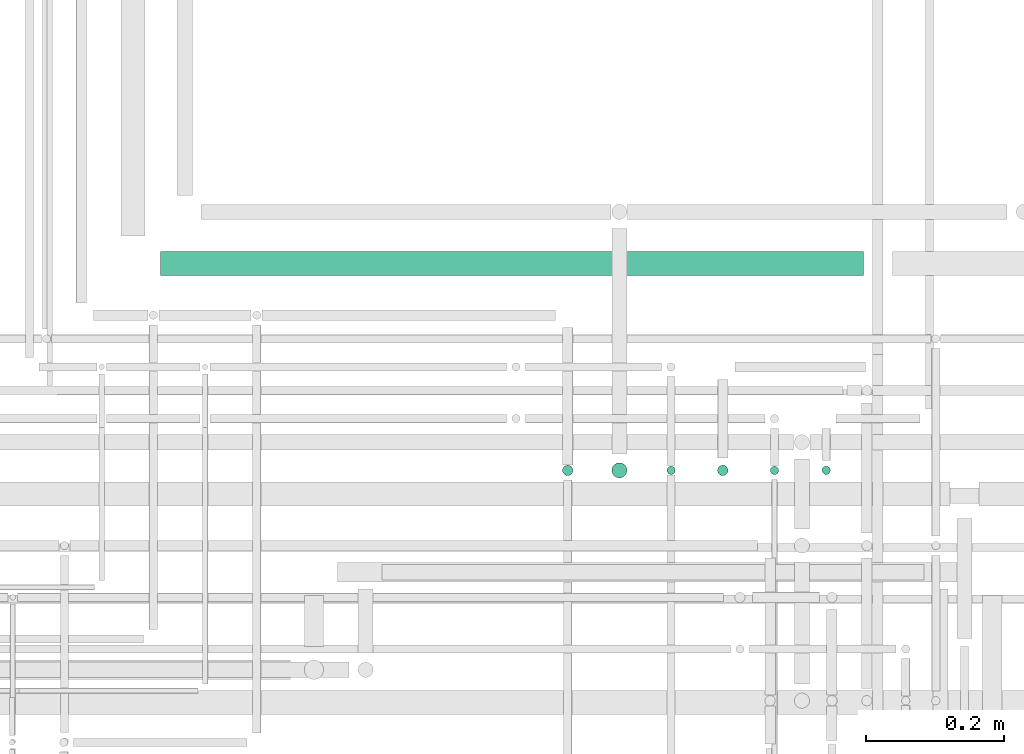
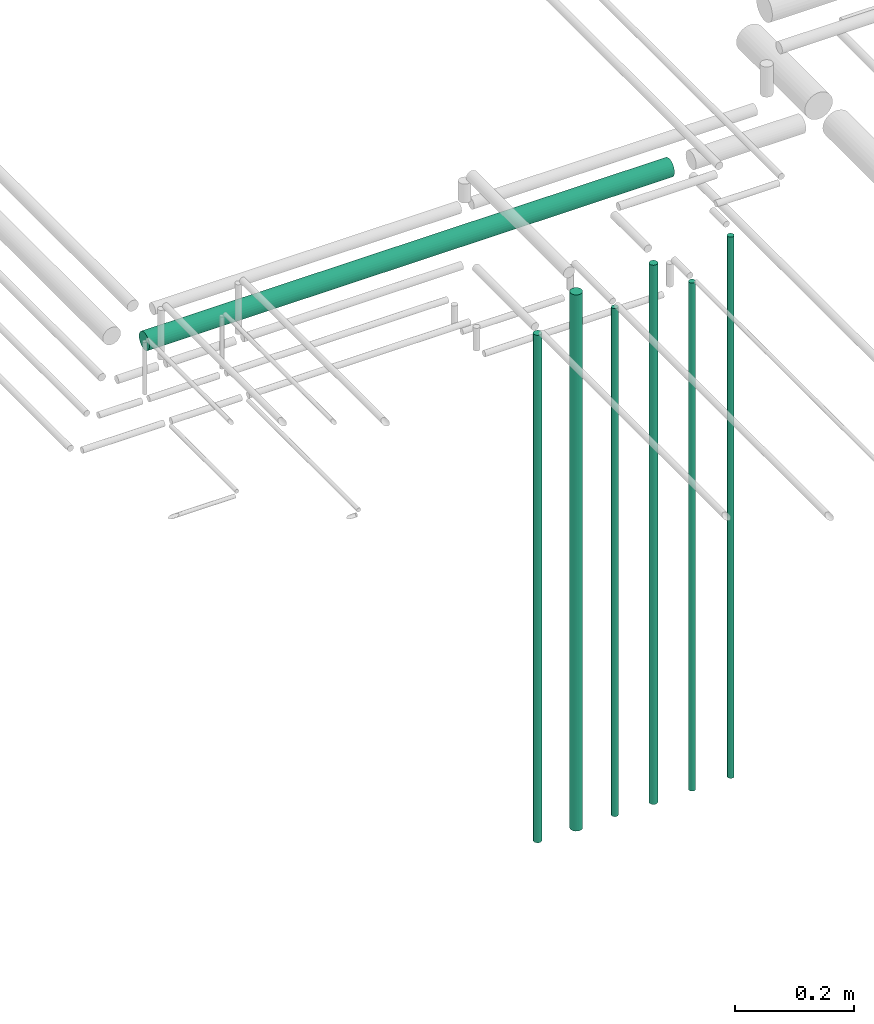
# One storey, part 84 of 331: 7 flow segments.
"""IFC2X3 building model written with IfcOpenShell, lengths in millimetres."""

from ifc_helpers import new_model, entity, si_unit, converted_unit, derived_unit, direction, frame, frame_2d, origin, origin_2d_with_axis, place, context, subcontext, project, spatial, circle, extrude, type_object, element, save


model = new_model("IFC2X3")

# Units and contexts
model_context = context("Model", 3, precision=0.01, world=origin(), true_north=direction((6.12303176911189e-17, 1.0)))
body_context = subcontext(model_context, "Body", "Model", "MODEL_VIEW")
ifc_project = project(units=[si_unit("LENGTHUNIT", "METRE", prefix="MILLI"), si_unit("AREAUNIT", "SQUARE_METRE"), si_unit("VOLUMEUNIT", "CUBIC_METRE"), converted_unit("PLANEANGLEUNIT", "DEGREE", entity("IfcRatioMeasure", 0.0174532925199433), si_unit("PLANEANGLEUNIT", "RADIAN"), dimensions=[0, 0, 0, 0, 0, 0, 0]), si_unit("MASSUNIT", "GRAM", prefix="KILO"), derived_unit("MASSDENSITYUNIT", [(si_unit("MASSUNIT", "GRAM", prefix="KILO"), 1), (si_unit("LENGTHUNIT", "METRE"), -3)]), derived_unit("MOMENTOFINERTIAUNIT", [(si_unit("LENGTHUNIT", "METRE"), 4)]), si_unit("TIMEUNIT", "SECOND"), si_unit("FREQUENCYUNIT", "HERTZ"), si_unit("THERMODYNAMICTEMPERATUREUNIT", "DEGREE_CELSIUS"), derived_unit("THERMALTRANSMITTANCEUNIT", [(si_unit("MASSUNIT", "GRAM", prefix="KILO"), 1), (si_unit("THERMODYNAMICTEMPERATUREUNIT", "KELVIN"), -1), (si_unit("TIMEUNIT", "SECOND"), -3)]), derived_unit("VOLUMETRICFLOWRATEUNIT", [(si_unit("LENGTHUNIT", "METRE"), 3), (si_unit("TIMEUNIT", "SECOND"), -1)]), derived_unit("MASSFLOWRATEUNIT", [(si_unit("MASSUNIT", "GRAM", prefix="KILO"), 1), (si_unit("TIMEUNIT", "SECOND"), -1)]), derived_unit("ROTATIONALFREQUENCYUNIT", [(si_unit("TIMEUNIT", "SECOND"), -1)]), si_unit("ELECTRICCURRENTUNIT", "AMPERE"), si_unit("ELECTRICVOLTAGEUNIT", "VOLT"), si_unit("POWERUNIT", "WATT"), si_unit("FORCEUNIT", "NEWTON", prefix="KILO"), si_unit("ILLUMINANCEUNIT", "LUX"), si_unit("LUMINOUSFLUXUNIT", "LUMEN"), si_unit("LUMINOUSINTENSITYUNIT", "CANDELA"), derived_unit("USERDEFINED", [(si_unit("MASSUNIT", "GRAM", prefix="KILO"), -1), (si_unit("LENGTHUNIT", "METRE"), -2), (si_unit("TIMEUNIT", "SECOND"), 3), (si_unit("LUMINOUSFLUXUNIT", "LUMEN"), 1)]), derived_unit("LINEARVELOCITYUNIT", [(si_unit("LENGTHUNIT", "METRE"), 1), (si_unit("TIMEUNIT", "SECOND"), -1)]), si_unit("PRESSUREUNIT", "PASCAL"), derived_unit("USERDEFINED", [(si_unit("LENGTHUNIT", "METRE"), -2), (si_unit("MASSUNIT", "GRAM", prefix="KILO"), 1), (si_unit("TIMEUNIT", "SECOND"), -2)]), derived_unit("LINEARFORCEUNIT", [(si_unit("MASSUNIT", "GRAM", prefix="KILO"), 1), (si_unit("LENGTHUNIT", "METRE"), 1), (si_unit("TIMEUNIT", "SECOND"), -2), (si_unit("LENGTHUNIT", "METRE"), -1)]), derived_unit("PLANARFORCEUNIT", [(si_unit("MASSUNIT", "GRAM", prefix="KILO"), 1), (si_unit("LENGTHUNIT", "METRE"), 1), (si_unit("TIMEUNIT", "SECOND"), -2), (si_unit("LENGTHUNIT", "METRE"), -2)])], contexts=[model_context])

# Site, building, storey
site_placement = place(None, frame((0.0, -0.00077364408347762, 0.0)))
site = spatial("IfcSite", under=ifc_project, at=site_placement, CompositionType="ELEMENT")
building_placement = place(site_placement, origin())
building = spatial("IfcBuilding", under=site, at=building_placement, CompositionType="ELEMENT")
storey_placement = place(building_placement, origin())
storey = spatial("IfcBuildingStorey", under=building, at=storey_placement, CompositionType="ELEMENT", Elevation=0.0)

# Flow segments
pipe_segment_type = type_object("IfcPipeSegmentType", PredefinedType="NOTDEFINED")
flow_segment_1_placement = place(storey_placement, frame((63343.5166110417, 8477.21546224653, 17400.0)))
element("IfcFlowSegment", 1, at=flow_segment_1_placement, inside=storey, type_object=pipe_segment_type, context=body_context, shape_type="SweptSolid", body=[
    extrude(circle(Radius=6.0, at=origin_2d_with_axis()), frame((7.59527223591454, 7.59527223591562, 0.0)), (0.0, 0.0, 1.0), 1111.00000000001),
])
flow_segment_2_placement = place(storey_placement, frame((63192.0166110417, 8475.71546224654, 17400.0)))
element("IfcFlowSegment", 2, at=flow_segment_2_placement, inside=storey, type_object=pipe_segment_type, context=body_context, shape_type="SweptSolid", body=[
    extrude(circle(Radius=7.5, at=origin_2d_with_axis()), frame((9.09527223591419, 9.09527223591636, 0.0)), (0.0, 0.0, 1.0), 1107.00000000002),
])
flow_segment_3_placement = place(storey_placement, frame((63038.5166110417, 8472.21546224653, 17400.0)))
element("IfcFlowSegment", 3, at=flow_segment_3_placement, inside=storey, type_object=pipe_segment_type, context=body_context, shape_type="SweptSolid", body=[
    extrude(circle(Radius=11.0, at=origin_2d_with_axis()), frame((12.5952722359134, 12.5952722359156, 0.0)), (0.0, 0.0, 1.0), 1101.00000000002),
])
flow_segment_4_placement = place(storey_placement, frame((63268.5166110417, 8477.21546224653, 17400.0)))
element("IfcFlowSegment", 4, at=flow_segment_4_placement, inside=storey, type_object=pipe_segment_type, context=body_context, shape_type="SweptSolid", body=[
    extrude(circle(Radius=6.0, at=origin_2d_with_axis()), frame((7.59527223591454, 7.59527223591562, 0.0)), (0.0, 0.0, 1.0), 1043.0),
])
flow_segment_5_placement = place(storey_placement, frame((63118.5166110417, 8477.21546224652, 17400.0)))
element("IfcFlowSegment", 5, at=flow_segment_5_placement, inside=storey, type_object=pipe_segment_type, context=body_context, shape_type="SweptSolid", body=[
    extrude(circle(Radius=6.0, at=origin_2d_with_axis()), frame((7.59527223591454, 7.59527223591562, 0.0)), (0.0, 0.0, 1.0), 1043.00000000006),
])
flow_segment_6_placement = place(storey_placement, frame((62967.0166110417, 8475.71546224652, 17400.0)))
element("IfcFlowSegment", 6, at=flow_segment_6_placement, inside=storey, type_object=pipe_segment_type, context=body_context, shape_type="SweptSolid", body=[
    extrude(circle(Radius=7.5, at=origin_2d_with_axis()), frame((9.09527223591419, 9.09527223591636, 0.0)), (0.0, 0.0, 1.0), 1042.0),
])
flow_segment_7_placement = place(building_placement, frame((62385.5243524318, 8765.7154622462, 18430.9047277641)))
element("IfcFlowSegment", 7, at=flow_segment_7_placement, inside=storey, type_object=pipe_segment_type, context=body_context, shape_type="SweptSolid", body=[
    extrude(circle(Radius=17.5, at=frame_2d((1.51601398101775e-11, 0.0), x_axis=(1.0, 0.0))), frame((0.0, 19.0952722359314, 19.0952722359163), z_axis=(1.0, 0.0, 0.0), x_axis=(0.0, 1.0, 0.0)), (0.0, 0.0, 1.0), 1019.58753084585),
])

save(model, "model.ifc")
